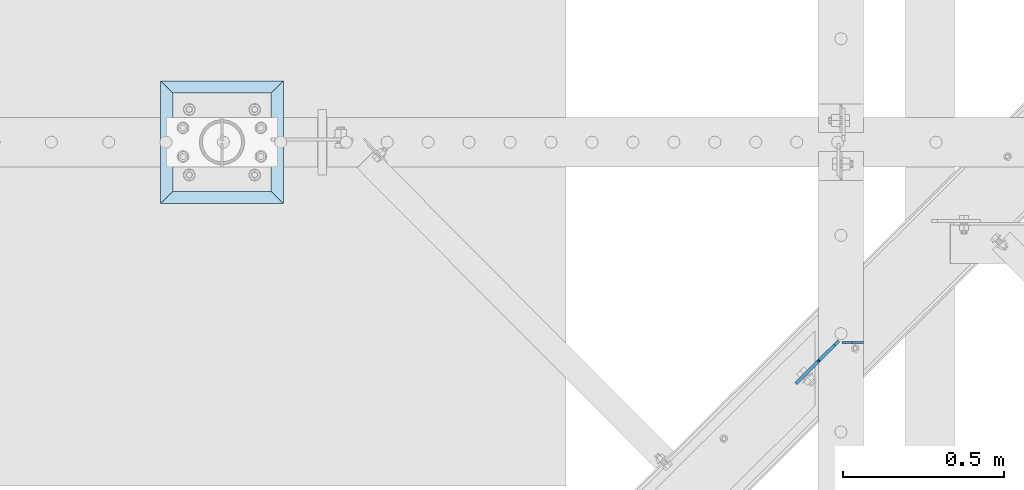
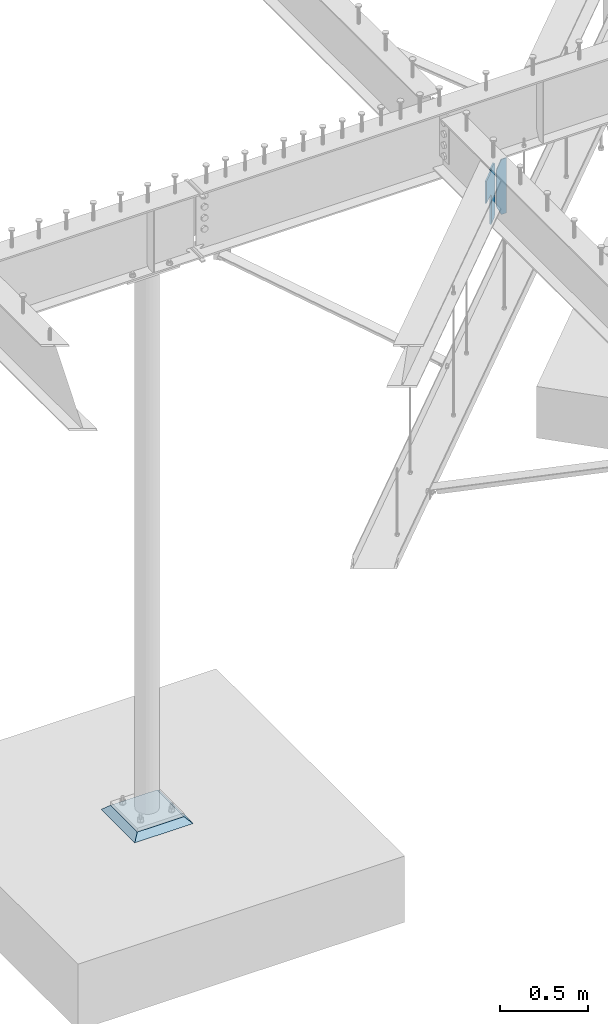
# One storey, part 857 of 975: 3 plates.
"""IFC2X3 building model written with IfcOpenShell, lengths in millimetres."""

from ifc_helpers import new_model, si_unit, frame, origin_with_axes, place, context, subcontext, project, spatial, faceted_brep, material, type_object, element, save


model = new_model("IFC2X3")

# Units and contexts
model_context = context("Model", 3, precision=1e-05, world=origin_with_axes())
body_context = subcontext(model_context, "Body", "Model", "MODEL_VIEW")
ifc_project = project(units=[si_unit("LENGTHUNIT", "METRE", prefix="MILLI"), si_unit("AREAUNIT", "SQUARE_METRE"), si_unit("VOLUMEUNIT", "CUBIC_METRE"), si_unit("MASSUNIT", "GRAM", prefix="KILO"), si_unit("TIMEUNIT", "SECOND"), si_unit("PLANEANGLEUNIT", "RADIAN"), si_unit("SOLIDANGLEUNIT", "STERADIAN"), si_unit("THERMODYNAMICTEMPERATUREUNIT", "DEGREE_CELSIUS"), si_unit("LUMINOUSINTENSITYUNIT", "LUMEN")], contexts=[model_context])

# Site, building, storey
site_placement = place(None, origin_with_axes())
site = spatial("IfcSite", under=ifc_project, at=site_placement, CompositionType="ELEMENT")
building_placement = place(site_placement, origin_with_axes())
building = spatial("IfcBuilding", under=site, at=building_placement, Name="Undefined", CompositionType="ELEMENT")
storey_placement = place(building_placement, origin_with_axes())
storey = spatial("IfcBuildingStorey", under=building, at=storey_placement, Name="Undefined", CompositionType="ELEMENT", Elevation=0.0)

# Plates
ifc_material_1 = material(Name="STEEL/A36")
plate_type_1 = type_object("IfcPlateType", PredefinedType="NOTDEFINED")
plate_1_placement = place(storey_placement, frame((26578.1075995318, 12716.2663250236, 3927.475), z_axis=(0.0, 0.0, -1.0), x_axis=(0.709199573009271, 0.70500777700921, 0.0)))
element("IfcPlate", 1, at=plate_1_placement, inside=storey, type_object=plate_type_1, material=ifc_material_1, Name="PLATE", context=body_context, shape_type="Brep", body=[
    faceted_brep([(0.0, -4.76250000000073, 0.0), (-3.63797880709171e-12, -4.762500000008, 3.17500019073486), (3.63797880709171e-12, 4.762500000008, 3.17500019073486), (0.0, 4.76250000000073, 0.0), (-0.966729922591185, -4.76250000000618, 8.03507970878036), (-0.966729922580271, 4.762500000008, 8.03507970878036), (-3.71974382306507, -4.76250000000437, 12.155256176934), (-3.71974382305416, 4.76250000001164, 12.155256176934), (-7.83992029121509, -4.76250000000073, 14.908270077412), (-7.83992029120782, 4.76250000001346, 14.908270077412), (-12.6999998092579, -4.76249999999709, 15.875), (-12.6999998092469, 4.76250000001892, 15.875), (-102.926330566297, -4.76249999991524, 15.875), (-102.92633056629, 4.76250000009713, 15.875), (-102.926330566297, -4.76249999991524, 168.274993896484), (-102.92633056629, 4.76250000009713, 168.274993896484), (-12.6999998092615, -4.76249999999709, 168.274993896484), (-12.6999998092469, 4.76250000001892, 168.274993896484), (-7.83992029121873, -4.76250000000073, 169.241723819072), (-7.83992029120782, 4.76250000001528, 169.241723819072), (-3.71974382306871, -4.76250000000437, 171.99473771955), (-3.71974382306144, 4.76250000000982, 171.99473771955), (-0.966729922591185, -4.762500000008, 176.114914187704), (-0.966729922587547, 4.762500000008, 176.114914187704), (-3.63797880709171e-12, -4.76250000000618, 180.97499370575), (0.0, 4.76250000000618, 180.97499370575), (-3.63797880709171e-12, -4.762500000008, 381.0), (3.63797880709171e-12, 4.762500000008, 381.0), (65.4957389830852, -4.76250000006075, 381.0), (65.4957389830925, 4.76249999995343, 381.0), (84.5457382201239, -4.76250000007713, 361.950000762939), (84.5457382201348, 4.76249999993888, 361.950000762939), (84.5457382201239, -4.76250000007713, 19.0499992370605), (84.5457382201348, 4.76249999993888, 19.0499992370605), (65.4957389830852, -4.76250000006075, 0.0), (65.4957389830925, 4.76249999995343, 0.0)], [[[0, 1, 2, 3]], [[1, 4, 5, 2]], [[4, 6, 7, 5]], [[6, 8, 9, 7]], [[8, 10, 11, 9]], [[10, 12, 13, 11]], [[12, 14, 15, 13]], [[14, 16, 17, 15]], [[16, 18, 19, 17]], [[18, 20, 21, 19]], [[20, 22, 23, 21]], [[22, 24, 25, 23]], [[24, 26, 27, 25]], [[26, 28, 29, 27]], [[28, 30, 31, 29]], [[30, 32, 33, 31]], [[32, 34, 35, 33]], [[34, 0, 3, 35]], [[5, 7, 9, 11, 13, 15, 17, 19, 21, 23, 25, 27, 29, 31, 33, 35, 3, 2]], [[34, 32, 30, 28, 26, 24, 22, 20, 18, 16, 14, 12, 10, 8, 6, 4, 1, 0]]]),
])
plate_type_2 = type_object("IfcPlateType", PredefinedType="NOTDEFINED")
plate_2_placement = place(storey_placement, frame((26714.45, 12771.1721102513, 3546.475), z_axis=(0.0, 0.0, 1.0), x_axis=(-0.999999999999998, 6.90000001668524e-08, 0.0)))
element("IfcPlate", 2, at=plate_2_placement, inside=storey, type_object=plate_type_2, material=ifc_material_1, Name="PLATE", context=body_context, shape_type="Brep", body=[
    faceted_brep([(0.0, -3.17499999999927, 0.0), (1.83717929758132e-10, -3.17499999972279, 381.000000000335), (1.90993887372315e-10, 3.17500000029031, 381.000000000333), (0.0, 3.17499999999927, 0.0), (34.9250030519688, -3.17499999970096, 381.000000000334), (34.9250030519761, 3.17500000031214, 381.000000000333), (66.6750030517578, -3.17499999999927, 315.912498474121), (66.6750030517578, 3.17499999999927, 315.912498474121), (66.6750030517578, -3.17499999999927, 65.0875015258789), (66.6750030517578, 3.17499999999927, 65.0875015258789), (34.9250030517815, -3.17499999998472, -1.81898940354586e-12), (34.9250030517906, 3.17500000002838, -1.81898940354586e-12)], [[[0, 1, 2, 3]], [[1, 4, 5, 2]], [[4, 6, 7, 5]], [[6, 8, 9, 7]], [[8, 10, 11, 9]], [[10, 0, 3, 11]], [[5, 7, 9, 11, 3, 2]], [[10, 8, 6, 4, 1, 0]]]),
])
ifc_material_2 = material(Name="CONCRETE/GROUT")
plate_type_3 = type_object("IfcPlateType", PredefinedType="NOTDEFINED")
plate_3_placement = place(storey_placement, frame((24915.8125, 13201.6500000001, -285.749999999999), z_axis=(-0.999999999999998, 6.90000001668524e-08, 0.0), x_axis=(0.0, 1.0, 0.0)))
element("IfcPlate", 3, at=plate_3_placement, inside=storey, type_object=plate_type_3, material=ifc_material_2, Name="GROUT", context=body_context, shape_type="Brep", body=[
    faceted_brep([(38.1000000096292, -19.05, 342.899999985777), (0.0, 19.05, 381.0), (2.63382389675826e-07, 19.0500000000138, 0.0), (38.1000000092372, -19.05, 38.1000000116328), (342.899999988684, -19.05, 38.1000000120257), (381.0, 19.05, 0.0), (381.0, 19.05, 381.0), (342.899999989076, -19.05, 342.89999998617)], [[[0, 1, 2, 3]], [[4, 5, 6, 7]], [[4, 7, 0, 3]], [[5, 4, 3, 2]], [[6, 5, 2, 1]], [[7, 6, 1, 0]]]),
])

save(model, "model.ifc")
